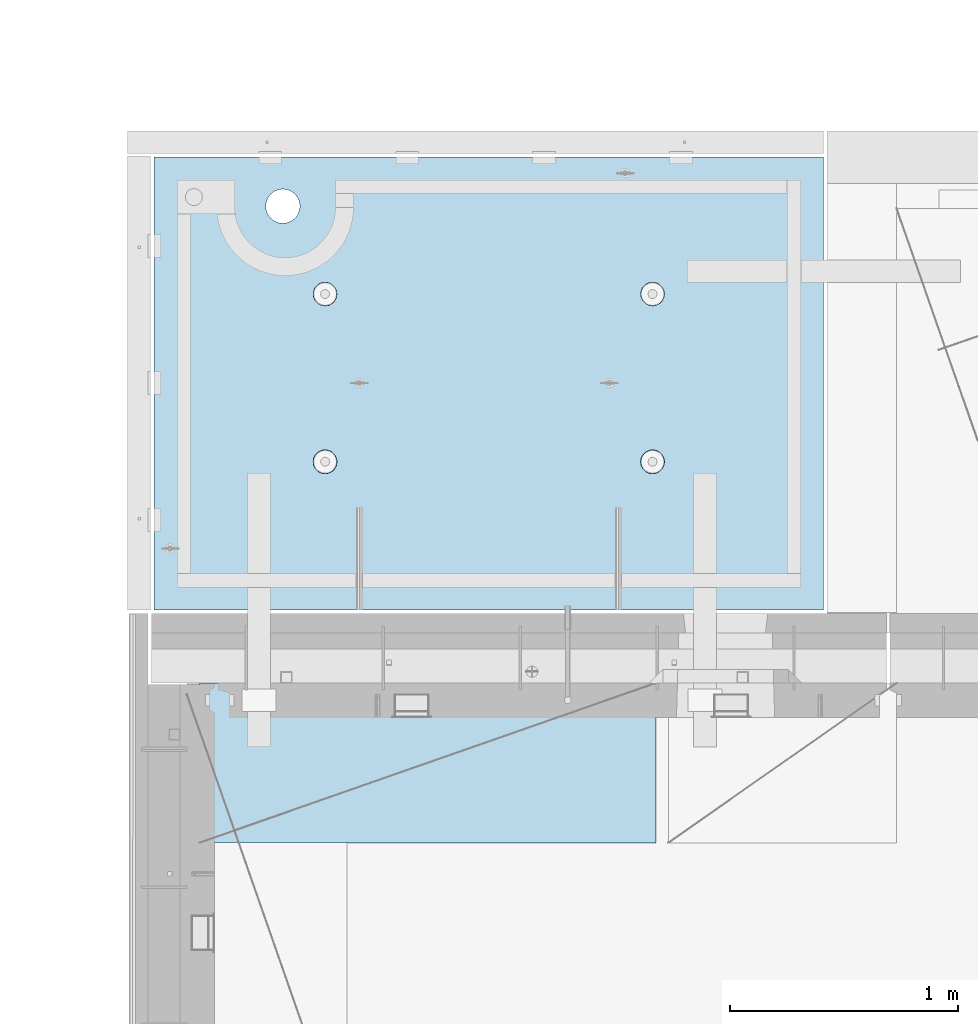
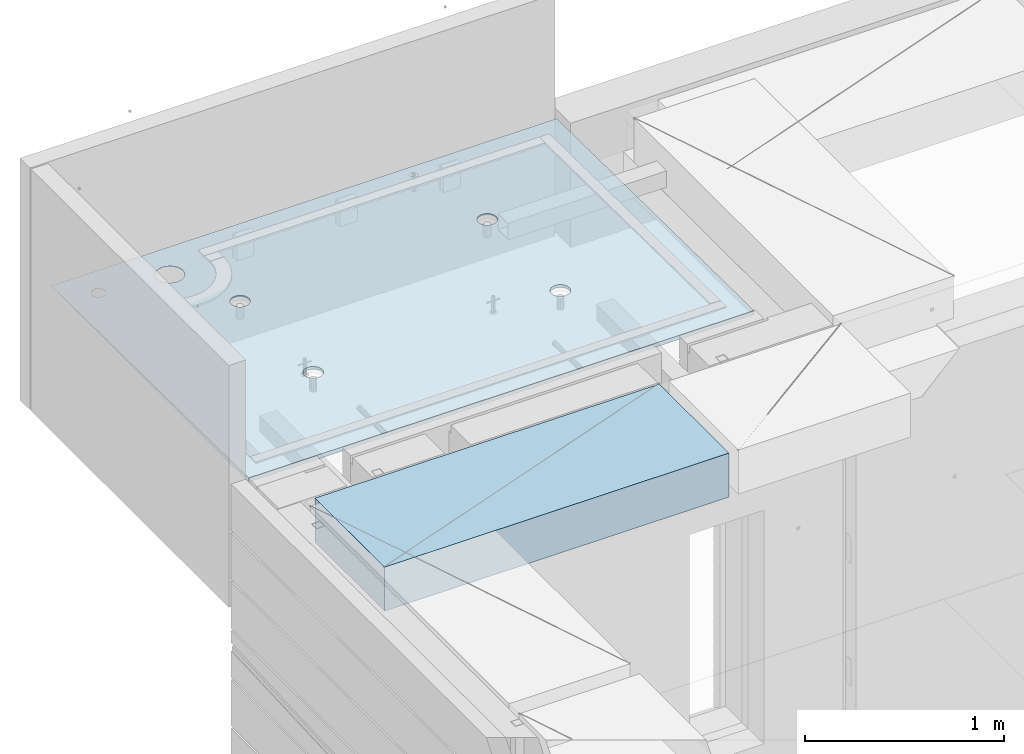
# One storey, part 184 of 325: 1 plate, 1 slab, 2 elements without a shape of their own.
"""IFC2X3 building model written with IfcOpenShell, lengths in millimetres."""

import ifcopenshell
import ifcopenshell.guid

model = None  # the IFC model being written
_history = None  # IfcOwnerHistory: only IFC2X3 demands one
_inside = {}  # id of a spatial element -> (the spatial element, [elements in it])
_under = {}  # id of a project, library or spatial element -> (it, [spatial elements below it])
_declared = {}  # id of a project -> (the project, [libraries it declares])
_typed = {}  # id of a type object -> (the type object, [elements of that type])
_made_of = {}  # id of a material, layer set ... -> (it, [elements and type objects made of it])


def new_model(schema):
    """Start an empty IFC model of exactly this schema.

    Asked for "IFC4X3", IfcOpenShell would pick the latest addendum, in which some entities
    have other attributes; the version numbers below select the first issue.
    IFC2X3 requires an IfcOwnerHistory on every rooted entity: one is made here for all.
    """
    global model, _history
    if schema == "IFC4X3":
        model = ifcopenshell.file(schema_version=(4, 3, 0, 0))
    else:
        model = ifcopenshell.file(schema=schema)
    _inside.clear()
    _under.clear()
    _declared.clear()
    _typed.clear()
    _made_of.clear()
    _history = None
    if model.schema == "IFC2X3":
        org = make("IfcOrganization", Name="unknown")
        user = make(
            "IfcPersonAndOrganization",
            ThePerson=make("IfcPerson", FamilyName="unknown"),
            TheOrganization=org,
        )
        app = make(
            "IfcApplication",
            ApplicationDeveloper=org,
            Version="unknown",
            ApplicationFullName="unknown",
            ApplicationIdentifier="unknown",
        )
        _history = make(
            "IfcOwnerHistory",
            OwningUser=user,
            OwningApplication=app,
            ChangeAction="ADDED",
            CreationDate=0,
        )
    return model


def make(cls, **values):
    """One entity of the class cls with the attributes given. An attribute that is None is left unset."""
    return model.create_entity(
        cls, **{name: value for name, value in values.items() if value is not None}
    )


def rooted(cls, **values):
    """An entity with a GlobalId (a new one), such as an element, a storey or a relation."""
    return make(cls, GlobalId=ifcopenshell.guid.new(), OwnerHistory=_history, **values)


def si_unit(unit_type, name, prefix=None):
    """IfcSIUnit, for example si_unit("LENGTHUNIT", "METRE", prefix="MILLI")."""
    return make("IfcSIUnit", UnitType=unit_type, Prefix=prefix, Name=name)


def assignment(units):
    """IfcUnitAssignment: the units of a project."""
    return None if units is None else make("IfcUnitAssignment", Units=units)


def point(xyz):
    """IfcCartesianPoint."""
    return None if xyz is None else make("IfcCartesianPoint", Coordinates=xyz)


def direction(xyz):
    """IfcDirection."""
    return None if xyz is None else make("IfcDirection", DirectionRatios=xyz)


def frame(location, z_axis=None, x_axis=None):
    """IfcAxis2Placement3D, a coordinate frame: its origin and axes. An axis left out is left unset."""
    return make(
        "IfcAxis2Placement3D",
        Location=point(location),
        Axis=direction(z_axis),
        RefDirection=direction(x_axis),
    )


def origin_with_axes():
    """The frame at (0, 0, 0) with the z axis (0, 0, 1) and the x axis (1, 0, 0) written out."""
    return frame((0.0, 0.0, 0.0), z_axis=(0.0, 0.0, 1.0), x_axis=(1.0, 0.0, 0.0))


def place(relative_to, where):
    """IfcLocalPlacement: puts the frame where relative to a parent placement (None: the world)."""
    return make(
        "IfcLocalPlacement", PlacementRelTo=relative_to, RelativePlacement=where
    )


def context(
    kind, dimensions, precision=None, world=None, true_north=None, identifier=None
):
    """IfcGeometricRepresentationContext, for example the 3D "Model" context."""
    return make(
        "IfcGeometricRepresentationContext",
        ContextIdentifier=identifier,
        ContextType=kind,
        CoordinateSpaceDimension=dimensions,
        Precision=precision,
        WorldCoordinateSystem=world,
        TrueNorth=true_north,
    )


def subcontext(parent, identifier, kind, view, scale=None):
    """IfcGeometricRepresentationSubContext, for example "Body" below "Model"."""
    return make(
        "IfcGeometricRepresentationSubContext",
        ContextIdentifier=identifier,
        ContextType=kind,
        ParentContext=parent,
        TargetScale=scale,
        TargetView=view,
    )


def project(units=None, contexts=None):
    """IfcProject with its units and contexts."""
    return rooted(
        "IfcProject",
        Name="project",
        RepresentationContexts=contexts,
        UnitsInContext=assignment(units),
    )


def spatial(cls, under=None, at=None, **own):
    """A site, building, storey or space (cls), placed at a placement, below another one or the project."""
    s = rooted(cls, ObjectPlacement=at, **own)
    if under is not None:
        _under.setdefault(under.id(), (under, []))[1].append(s)
    return s


def faces_of(points, faces, orient=None, outer=None):
    """IfcFace entities. A face is a list of loops; a loop is a list of indices into points, from 0.

    orient and outer hold one flag for each loop. By default every Orientation is true, the
    first loop of a face is its IfcFaceOuterBound and the others are IfcFaceBound.
    """
    made = []
    for i, loops in enumerate(faces):
        bounds = []
        for j, loop in enumerate(loops):
            is_outer = j == 0 if outer is None else outer[i][j]
            bounds.append(
                make(
                    "IfcFaceOuterBound" if is_outer else "IfcFaceBound",
                    Bound=make("IfcPolyLoop", Polygon=[points[k] for k in loop]),
                    Orientation=True if orient is None else orient[i][j],
                )
            )
        made.append(make("IfcFace", Bounds=bounds))
    return made


def faceted_brep(points, faces, orient=None, outer=None, voids=None):
    """IfcFacetedBrep: a solid bounded by flat faces; with voids (closed shells), ...WithVoids."""
    shared = [point(p) for p in points]
    hull = make("IfcClosedShell", CfsFaces=faces_of(shared, faces, orient, outer))
    if voids is None:
        return make("IfcFacetedBrep", Outer=hull)
    return make(
        "IfcFacetedBrepWithVoids",
        Outer=hull,
        Voids=[
            make(cls, CfsFaces=faces_of(shared, fs, o, b)) for cls, fs, o, b in voids
        ],
    )


def shape(context_of_items, identifier, shape_type, items):
    """IfcShapeRepresentation: the items that make up one representation, for example the "Body"."""
    return make(
        "IfcShapeRepresentation",
        ContextOfItems=context_of_items,
        RepresentationIdentifier=identifier,
        RepresentationType=shape_type,
        Items=items,
    )


def material(Name=None, Category=None):
    """IfcMaterial."""
    return make("IfcMaterial", Name=Name, Category=Category)


def made_of(thing, what):
    """Note that an element or type object is made of a material, layer set ...; save() writes the relation."""
    if what is not None:
        _made_of.setdefault(what.id(), (what, []))[1].append(thing)
    return thing


def type_object(cls, material=None, **own):
    """A type object (cls), such as IfcWallType, which elements share."""
    return made_of(rooted(cls, **own), material)


def element(
    cls,
    number,
    at=None,
    inside=None,
    cuts=None,
    type_object=None,
    material=None,
    context=None,
    identifier="Body",
    shape_type=None,
    held_by="IfcProductDefinitionShape",
    body=None,
    shapes=None,
    **own,
):
    """One element of the class cls, such as IfcWall. Its Tag is "e" and its number.

    at: its placement. inside: the storey or other place that contains it. cuts: it is an
    opening in that element (IfcRelVoidsElement). A single representation is given by context,
    identifier, shape_type and body (its items); several are given by shapes. held_by: the class
    of the entity that holds the representations. save() writes the other relations.
    """
    e = rooted(cls, Tag="e%d" % number, ObjectPlacement=at, **own)
    if body is not None:
        shapes = [shape(context, identifier, shape_type, body)]
    if shapes is not None:
        e.Representation = make(held_by, Representations=shapes)
    if inside is not None:
        _inside.setdefault(inside.id(), (inside, []))[1].append(e)
    if cuts is not None:
        rooted(
            "IfcRelVoidsElement", RelatingBuildingElement=cuts, RelatedOpeningElement=e
        )
    if type_object is not None:
        _typed.setdefault(type_object.id(), (type_object, []))[1].append(e)
    return made_of(e, material)


def aggregate(whole, parts):
    """IfcRelAggregates: a whole, such as a stair, and the parts it consists of."""
    return rooted("IfcRelAggregates", RelatingObject=whole, RelatedObjects=parts)


def save(model, path):
    """Write the relations noted so far, then the file.

    IfcRelAggregates (storeys below a building ...), IfcRelContainedInSpatialStructure (elements
    in a storey), IfcRelDefinesByType, IfcRelAssociatesMaterial and IfcRelDeclares: one each for
    every whole, place, type object, material and project.
    """
    for whole, parts in _under.values():
        aggregate(whole, parts)
    for where, things in _inside.values():
        rooted(
            "IfcRelContainedInSpatialStructure",
            RelatedElements=things,
            RelatingStructure=where,
        )
    for kind, things in _typed.values():
        rooted("IfcRelDefinesByType", RelatedObjects=things, RelatingType=kind)
    for what, things in _made_of.values():
        rooted("IfcRelAssociatesMaterial", RelatedObjects=things, RelatingMaterial=what)
    for by, libraries in _declared.values():
        rooted("IfcRelDeclares", RelatingContext=by, RelatedDefinitions=libraries)
    model.write(path)


model = new_model("IFC2X3")

# Units and contexts
model_context = context("Model", 3, precision=1e-05, world=origin_with_axes())
body_context = subcontext(model_context, "Body", "Model", "MODEL_VIEW")
ifc_project = project(units=[si_unit("LENGTHUNIT", "METRE", prefix="MILLI"), si_unit("AREAUNIT", "SQUARE_METRE"), si_unit("VOLUMEUNIT", "CUBIC_METRE"), si_unit("MASSUNIT", "GRAM", prefix="KILO"), si_unit("TIMEUNIT", "SECOND"), si_unit("PLANEANGLEUNIT", "RADIAN"), si_unit("SOLIDANGLEUNIT", "STERADIAN"), si_unit("THERMODYNAMICTEMPERATUREUNIT", "DEGREE_CELSIUS"), si_unit("LUMINOUSINTENSITYUNIT", "LUMEN")], contexts=[model_context])

# Site, building, storey
site_placement = place(None, origin_with_axes())
site = spatial("IfcSite", under=ifc_project, at=site_placement, CompositionType="ELEMENT")
building_placement = place(site_placement, origin_with_axes())
building = spatial("IfcBuilding", under=site, at=building_placement, CompositionType="ELEMENT")
storey_placement = place(building_placement, origin_with_axes())
storey = spatial("IfcBuildingStorey", under=building, at=storey_placement, Name="1", CompositionType="ELEMENT", Elevation=0.0)

# Assembly, slab
assembly_1_placement = place(storey_placement, origin_with_axes())
assembly_1 = element("IfcElementAssembly", 1, at=assembly_1_placement, inside=storey, AssemblyPlace="NOTDEFINED", PredefinedType="REINFORCEMENT_UNIT")
ifc_material_1 = material(Name="CONCRETE/C35/45")
slab_type = type_object("IfcSlabType", PredefinedType="NOTDEFINED")
slab_placement = place(assembly_1_placement, frame((7734.99985681325, 20899.9965573523, 84717.5), z_axis=(0.0, 1.0, 0.0), x_axis=(1.0, 0.0, 0.0)))
slab = element("IfcSlab", 2, at=slab_placement, type_object=slab_type, material=ifc_material_1, PredefinedType="FLOOR", context=body_context, shape_type="Brep", body=[
    faceted_brep([(209.64691778923, 10.1153411067935, 1795.66138892724), (209.64691778923, 12.5000000975269, 1795.66138892724), (201.519156607756, 12.5000000956934, 1783.49470026561), (201.519156607756, 9.96210853298544, 1783.49470026561), (189.354094229504, 12.5000000940054, 1775.36450517907), (189.354094229504, 9.85971331609471, 1775.36450517907), (175.003751124998, 12.5000000927103, 1772.50855216914), (175.003751124998, 9.82374419966072, 1772.50855216914), (160.652836945715, 12.5000000920118, 1775.36163419229), (160.652836945715, 9.85967715564766, 1775.36163419229), (148.48614828409, 12.5000000919972, 1783.48939537376), (148.48614828409, 9.96204171716818, 1783.48939537376), (140.355953197546, 12.5000000926811, 1795.65445775201), (140.355953197546, 10.1152538077149, 1795.65445775201), (137.500000187611, 12.5000000939617, 1810.00480085652), (137.500000187611, 10.2959882753639, 1810.00480085652), (140.353082210766, 12.5000000956497, 1824.35571503581), (140.353082210766, 10.4767299357773, 1824.35571503581), (148.48084339224, 12.5000000974687, 1836.52240369743), (148.48084339224, 10.6299625095853, 1836.52240369743), (160.645905770492, 12.5000000991568, 1844.65259878397), (160.645905770492, 10.7323577264906, 1844.65259878397), (174.996248874998, 12.5000001004519, 1847.50855179391), (174.996248874998, 10.76832684291, 1847.50855179391), (189.347163054282, 12.5000001011649, 1844.65546977075), (189.347163054282, 10.7323938869522, 1844.65546977075), (201.513851715907, 12.5000001011795, 1836.52770858928), (201.513851715907, 10.6300293254026, 1836.52770858928), (209.64404680245, 12.500000100481, 1824.36264621103), (209.64404680245, 10.4768172348558, 1824.36264621103), (212.499999812386, 12.5000000992004, 1810.01230310652), (212.499999812386, 10.2960827672068, 1810.01230310652), (7.41420080885291e-08, 12.4999999999927, 0.0), (-7.41420080885291e-08, -12.5, -3.63797880709171e-12), (0.0, 12.5, 1985.00366210938), (2935.0, 12.5, 0.0), (2935.0, 12.5000004097383, 1985.00366209901), (2935.0, -12.5, 0.0), (2234.62536650318, -4.11052952855243, 666.125174646004), (2233.6850359994, 12.5000001221924, 665.819642744358), (2236.1904762364, 12.5000001207372, 650.000915653603), (2237.19128609271, -4.31360546511132, 650.000915653603), (2227.20504000945, -3.927412769277, 680.664672078045), (2226.41396523543, 12.5000001231529, 680.089922611885), (2215.65867395993, -3.78214492548432, 692.198960124559), (2215.08900701139, 12.5000001235312, 691.414880835895), (2201.11650369535, -3.68890261078195, 699.602413590121), (2200.81872714385, 12.5000001232838, 698.685951599829), (2185.00000005312, -3.65677809614863, 702.153104825993), (2185.00000005312, 12.5000001224398, 701.19139183679), (2168.88349641084, -3.6889026130375, 699.602413590248), (2169.18127296234, 12.5000001210865, 698.685951599953), (2154.34132614616, -3.78214492976258, 692.198960124762), (2154.9109930947, 12.5000001193257, 691.414880836099), (2142.7949600965, -3.92741277518508, 680.664672078252), (2143.58603487053, 12.5000001173757, 680.089922612086), (2135.37463360266, -4.11052953547915, 666.125174646131), (2136.31496410644, 12.5000001153967, 665.819642744485), (2132.80871401309, -4.31360547240183, 650.000915653603), (2133.8095238694, 12.5000001135923, 650.000915653603), (2135.35163581154, -4.51677552006731, 633.869184225769), (2136.31496410626, 12.5000001121371, 634.182188562663), (2142.75774888357, -4.70013866545924, 619.310123700241), (2143.58603487023, 12.5000001111621, 619.911908694903), (2154.30411492676, -4.84571105932991, 607.751654332831), (2154.9109930944, 12.5000001107837, 608.586950470697), (2168.86049860927, -4.93919976030884, 600.328637761646), (2169.18127296215, 12.5000001110311, 601.315879706683), (2185.00000005312, -4.97141838613607, 597.770474083001), (2185.00000005312, 12.5000001118751, 598.810439469788), (2201.13950149693, -4.93919975805329, 600.328637761777), (2200.81872714404, 12.500000113243, 601.31587970681), (2215.69588517932, -4.84571105505165, 607.751654333038), (2215.08900701168, 12.5000001149892, 608.586950470901), (2227.24225122238, -4.70013865955116, 619.310123700448), (2226.41396523573, 12.5000001169392, 619.911908695103), (2234.6483642943, -4.5167755131406, 633.869184225896), (2233.68503599959, 12.5000001189328, 634.182188562787), (799.625366508852, -4.11052962872782, 666.125174647848), (798.685036005074, 12.5000000220316, 665.819642746203), (801.190476242367, 12.5000000205619, 650.000915653603), (802.19128609867, -4.31360556531581, 650.000915653603), (792.205040014274, -3.92741286943783, 680.664672081548), (791.41396524025, 12.500000022992, 680.089922615389), (780.658673963429, -3.78214502561605, 692.198960129379), (780.089007014889, 12.5000000233704, 691.414880840719), (766.116503697189, -3.68890271089913, 699.602413595789), (765.818727145695, 12.500000023123, 698.685951605497), (750.000000053116, -3.65677819628036, 702.153104831952), (750.000000053116, 12.500000022279, 701.191391842753), (733.883496409002, -3.68890271315468, 699.602413595916), (734.181272960497, 12.5000000209257, 698.685951605625), (719.341326142654, -3.78214502989431, 692.198960129586), (719.910993091196, 12.5000000191649, 691.414880840923), (707.794960091675, -3.9274128753168, 680.664672081755), (708.586034865702, 12.5000000172149, 680.089922615593), (700.374633596988, -4.11052963565453, 666.125174647976), (701.314964100775, 12.5000000152359, 665.819642746326), (697.808714007129, -4.31360557259177, 650.000915653603), (698.80952386344, 12.5000000134314, 650.000915653603), (700.351635805864, -4.51677562028635, 633.869184223928), (701.314964100589, 12.5000000119617, 634.182188560822), (707.757748878739, -4.70013876570738, 619.310123696734), (708.586034865404, 12.5000000110012, 619.911908691396), (719.304114923256, -4.84571115959261, 607.751654328004), (719.910993090896, 12.5000000106229, 608.586950465873), (733.860498607421, -4.93919986057153, 600.328637755971), (734.181272960313, 12.5000000108703, 601.315879701015), (750.000000053116, -4.97141848641331, 597.770474077031), (750.000000053116, 12.5000000117143, 598.810439463825), (766.13950149877, -4.93919985831599, 600.328637756098), (765.818727145879, 12.5000000130822, 601.315879701138), (780.695885182828, -4.8457111552998, 607.751654328211), (780.089007015189, 12.5000000148284, 608.586950466077), (792.242251227208, -4.7001387597993, 619.310123696941), (791.413965240548, 12.5000000167784, 619.9119086916), (799.648364299976, -4.51677561334509, 633.869184224055), (798.685036005258, 12.500000018772, 634.182188560946), (799.10144812637, 5.14425941386435, 1400.95677429027), (798.685035917459, 12.5000000978907, 1400.82147376184), (801.190476154532, 12.5000000964355, 1385.00274667064), (801.640278098052, 4.94332744530402, 1385.00274667064), (791.759461503394, 5.32544292352395, 1415.3427714214), (791.413965153277, 12.5000000988512, 1415.09175362977), (780.334995861451, 5.46917710648268, 1426.75528657348), (780.089006928914, 12.5000000992295, 1426.4167118541), (765.946354116128, 5.56143501828774, 1434.08057830477), (765.818727060978, 12.5000000989821, 1433.68778261824), (749.999999969796, 5.59322037934908, 1436.60434069568), (749.999999969796, 12.5000000981381, 1436.19322285528), (734.053645823422, 5.56143501607585, 1434.0805783049), (734.181272878572, 12.5000000967848, 1433.68778261837), (719.665004077991, 5.46917710226262, 1426.75528657369), (719.91099301053, 12.5000000950386, 1426.41671185431), (708.240538435917, 5.32544291768863, 1415.34277142161), (708.586034786036, 12.5000000930741, 1415.09175362997), (700.898551812832, 5.1442594070104, 1400.9567742904), (701.314964021747, 12.500000091095, 1400.82147376197), (698.359721841111, 4.94332743810082, 1385.00274667064), (698.809523784634, 12.500000089276, 1385.00274667064), (700.875796820188, 4.74230235200957, 1369.04132550559), (701.314964021563, 12.5000000878208, 1369.18401957925), (708.203720079233, 4.56087505744654, 1354.63597181773), (708.586034785736, 12.5000000868604, 1354.91373971109), (719.628185714913, 4.41683953967004, 1343.19953063831), (719.91099301023, 12.500000086482, 1343.58878148656), (734.030890820433, 4.32433784281602, 1335.85488233829), (734.181272878388, 12.5000000867294, 1336.31771072235), (749.999999969796, 4.292459364151, 1333.3237263947), (749.999999969796, 12.5000000875589, 1333.81227048538), (765.969109119118, 4.32433784505702, 1335.85488233842), (765.818727061163, 12.5000000889413, 1336.31771072247), (780.371814224529, 4.4168395439192, 1343.19953063852), (780.089006929215, 12.500000090673, 1343.58878148677), (791.796279860078, 4.5608750632673, 1354.63597181794), (791.413965153577, 12.5000000926375, 1354.91373971129), (799.124203119014, 4.74230235887808, 1369.04132550571), (798.685035917644, 12.5000000946166, 1369.18401957938), (2234.1014481207, 5.14425951402518, 1400.95677428843), (2233.68503591179, 12.5000001980516, 1400.82147376), (2236.19047614857, 12.5000001965964, 1385.00274667064), (2236.64027809209, 4.94332754549396, 1385.00274667064), (2226.75946149857, 5.32544302367023, 1415.3427714179), (2226.41396514845, 12.5000001990265, 1415.09175362627), (2215.33499585795, 5.46917720662896, 1426.75528656866), (2215.08900692541, 12.5000001993903, 1426.41671184928), (2200.94635411429, 5.56143511841947, 1434.0805782991), (2200.81872705914, 12.5000001991575, 1433.68778261257), (2184.9999999698, 5.5932204794517, 1436.60434068972), (2184.9999999698, 12.5000001982989, 1436.19322284931), (2169.05364582526, 5.56143511619302, 1434.08057829923), (2169.18127288041, 12.5000001969456, 1433.6877826127), (2154.66500408149, 5.46917720239435, 1426.75528656886), (2154.91099301403, 12.5000001951994, 1426.41671184948), (2143.24053844074, 5.32544301784947, 1415.3427714181), (2143.58603479086, 12.5000001932349, 1415.09175362647), (2135.8985518185, 5.14425950717123, 1400.95677428856), (2136.31496402742, 12.5000001912558, 1400.82147376013), (2133.35972184708, 4.94332753829076, 1385.00274667064), (2133.8095237906, 12.5000001894368, 1385.00274667064), (2135.87579682586, 4.74230245222861, 1369.04132550743), (2136.31496402723, 12.5000001879816, 1369.18401958109), (2143.20372008406, 4.56087515768013, 1354.63597182124), (2143.58603479056, 12.5000001870212, 1354.91373971459), (2154.62818571842, 4.41683963991818, 1343.19953064314), (2154.91099301373, 12.5000001866429, 1343.58878149139), (2169.03089082228, 4.32433794307872, 1335.85488234397), (2169.18127288023, 12.5000001868902, 1336.31771072802), (2184.9999999698, 4.2924594644137, 1333.32372640067), (2184.9999999698, 12.5000001877343, 1333.81227049134), (2200.96910911727, 4.32433794530516, 1335.85488234409), (2200.81872705932, 12.5000001891021, 1336.31771072814), (2215.37181422102, 4.41683964416734, 1343.19953064335), (2215.08900692571, 12.5000001908338, 1343.58878149159), (2226.79627985525, 4.56087516351545, 1354.63597182144), (2226.41396514875, 12.5000001927983, 1354.9137397148), (2234.12420311334, 4.74230245909712, 1369.04132550756), (2233.68503591197, 12.5000001947919, 1369.18401958122), (629.950843674942, 9.32008998414676, 1732.51833148514), (618.0319469801, 9.12446051153529, 1716.98532289615), (602.498938391109, 8.97434873710154, 1705.06642620131), (584.410366773798, 8.87998453022738, 1697.57389451346), (564.998938391109, 8.84779865563905, 1695.01833148514), (545.587510008419, 8.87998452752072, 1697.57389451346), (527.498938391109, 8.97434873186285, 1705.06642620131), (511.965929802118, 9.12446050412836, 1716.98532289615), (500.047033107276, 9.32008997508092, 1732.51833148514), (492.554501419429, 9.54790531957406, 1750.60690310245), (489.998938391109, 9.79238129836449, 1770.01833148514), (492.554501419429, 10.0368572775042, 1789.42975986783), (500.047033107276, 10.264672623045, 1807.51833148514), (511.965929802118, 10.4603020956565, 1823.05134007413), (527.498938391109, 10.6104138700903, 1834.97023676898), (545.587510008419, 10.7047780769644, 1842.46276845682), (564.998938391109, 10.7369639515528, 1845.01833148514), (584.410366773798, 10.7047780796856, 1842.46276845682), (602.498938391109, 10.610413875329, 1834.97023676898), (618.0319469801, 10.4603021030634, 1823.05134007413), (629.950843674942, 10.2646726321109, 1807.51833148514), (637.443375362789, 10.0368572876178, 1789.42975986783), (639.998938391109, 9.79238130884187, 1770.01833148514), (637.443375362789, 9.54790532968764, 1750.60690310245), (629.950843674942, 12.500000128086, 1807.51833148514), (637.443375362789, 12.5000001267326, 1789.42975986783), (618.0319469801, 12.5000001288572, 1823.05134007413), (602.498938391109, 12.5000001290027, 1834.97023676898), (584.410366773798, 12.500000128508, 1842.46276845682), (564.998938391109, 12.5000001274166, 1845.01833148514), (545.587510008419, 12.5000001258013, 1842.46276845682), (527.498938391109, 12.500000123764, 1834.97023676898), (511.965929802118, 12.5000001214503, 1823.05134007413), (500.047033107276, 12.5000001190201, 1807.51833148514), (492.554501419429, 12.5000001166336, 1789.42975986783), (489.998938391109, 12.5000001144508, 1770.01833148514), (492.554501419429, 12.5000001126173, 1750.60690310245), (500.047033107276, 12.5000001112785, 1732.51833148514), (511.965929802118, 12.5000001105072, 1716.98532289615), (527.498938391109, 12.5000001103617, 1705.06642620131), (545.587510008419, 12.5000001108419, 1697.57389451346), (564.998938391109, 12.5000001119333, 1695.01833148514), (584.410366773798, 12.5000001135631, 1697.57389451346), (602.498938391109, 12.5000001156004, 1705.06642620131), (618.0319469801, 12.5000001179142, 1716.98532289615), (629.950843674942, 12.5000001203443, 1732.51833148514), (637.443375362789, 12.5000001227309, 1750.60690310245), (639.998938391109, 12.5000001249136, 1770.01833148514)], [[[0, 1, 2, 3]], [[3, 2, 4, 5]], [[5, 4, 6, 7]], [[7, 6, 8, 9]], [[9, 8, 10, 11]], [[11, 10, 12, 13]], [[13, 12, 14, 15]], [[15, 14, 16, 17]], [[17, 16, 18, 19]], [[19, 18, 20, 21]], [[21, 20, 22, 23]], [[23, 22, 24, 25]], [[25, 24, 26, 27]], [[27, 26, 28, 29]], [[29, 28, 30, 31]], [[31, 30, 1, 0]], [[32, 33, 34]], [[35, 36, 37]], [[32, 35, 37, 33]], [[38, 39, 40, 41]], [[42, 43, 39, 38]], [[44, 45, 43, 42]], [[46, 47, 45, 44]], [[48, 49, 47, 46]], [[50, 51, 49, 48]], [[51, 50, 52, 53]], [[53, 52, 54, 55]], [[55, 54, 56, 57]], [[57, 56, 58, 59]], [[59, 58, 60, 61]], [[61, 60, 62, 63]], [[63, 62, 64, 65]], [[65, 64, 66, 67]], [[67, 66, 68, 69]], [[70, 71, 69, 68]], [[72, 73, 71, 70]], [[74, 75, 73, 72]], [[76, 77, 75, 74]], [[41, 40, 77, 76]], [[78, 79, 80, 81]], [[82, 83, 79, 78]], [[84, 85, 83, 82]], [[86, 87, 85, 84]], [[88, 89, 87, 86]], [[90, 91, 89, 88]], [[91, 90, 92, 93]], [[93, 92, 94, 95]], [[95, 94, 96, 97]], [[97, 96, 98, 99]], [[99, 98, 100, 101]], [[101, 100, 102, 103]], [[103, 102, 104, 105]], [[105, 104, 106, 107]], [[107, 106, 108, 109]], [[110, 111, 109, 108]], [[112, 113, 111, 110]], [[114, 115, 113, 112]], [[116, 117, 115, 114]], [[81, 80, 117, 116]], [[118, 119, 120, 121]], [[122, 123, 119, 118]], [[124, 125, 123, 122]], [[126, 127, 125, 124]], [[128, 129, 127, 126]], [[130, 131, 129, 128]], [[132, 133, 131, 130]], [[134, 135, 133, 132]], [[135, 134, 136, 137]], [[137, 136, 138, 139]], [[139, 138, 140, 141]], [[141, 140, 142, 143]], [[143, 142, 144, 145]], [[145, 144, 146, 147]], [[147, 146, 148, 149]], [[149, 148, 150, 151]], [[152, 153, 151, 150]], [[154, 155, 153, 152]], [[156, 157, 155, 154]], [[121, 120, 157, 156]], [[158, 159, 160, 161]], [[162, 163, 159, 158]], [[164, 165, 163, 162]], [[166, 167, 165, 164]], [[168, 169, 167, 166]], [[170, 171, 169, 168]], [[172, 173, 171, 170]], [[174, 175, 173, 172]], [[175, 174, 176, 177]], [[177, 176, 178, 179]], [[179, 178, 180, 181]], [[181, 180, 182, 183]], [[183, 182, 184, 185]], [[185, 184, 186, 187]], [[187, 186, 188, 189]], [[189, 188, 190, 191]], [[192, 193, 191, 190]], [[194, 195, 193, 192]], [[196, 197, 195, 194]], [[161, 160, 197, 196]], [[36, 34, 33, 37], [3, 5, 7, 9, 11, 13, 15, 17, 19, 21, 23, 25, 27, 29, 31, 0], [198, 199, 200, 201, 202, 203, 204, 205, 206, 207, 208, 209, 210, 211, 212, 213, 214, 215, 216, 217, 218, 219, 220, 221], [194, 192, 190, 188, 186, 184, 182, 180, 178, 176, 174, 172, 170, 168, 166, 164, 162, 158, 161, 196], [154, 152, 150, 148, 146, 144, 142, 140, 138, 136, 134, 132, 130, 128, 126, 124, 122, 118, 121, 156], [114, 112, 110, 108, 106, 104, 102, 100, 98, 96, 94, 92, 90, 88, 86, 84, 82, 78, 81, 116], [74, 72, 70, 68, 66, 64, 62, 60, 58, 56, 54, 52, 50, 48, 46, 44, 42, 38, 41, 76]], [[218, 222, 223, 219]], [[217, 224, 222, 218]], [[216, 225, 224, 217]], [[215, 226, 225, 216]], [[214, 227, 226, 215]], [[213, 228, 227, 214]], [[212, 229, 228, 213]], [[211, 230, 229, 212]], [[210, 231, 230, 211]], [[209, 232, 231, 210]], [[208, 233, 232, 209]], [[207, 234, 233, 208]], [[206, 235, 234, 207]], [[205, 236, 235, 206]], [[204, 237, 236, 205]], [[203, 238, 237, 204]], [[202, 239, 238, 203]], [[201, 240, 239, 202]], [[200, 241, 240, 201]], [[199, 242, 241, 200]], [[198, 243, 242, 199]], [[221, 244, 243, 198]], [[220, 245, 244, 221]], [[219, 223, 245, 220]], [[35, 32, 34, 36], [26, 24, 22, 20, 18, 16, 14, 12, 10, 8, 6, 4, 2, 1, 30, 28], [222, 224, 225, 226, 227, 228, 229, 230, 231, 232, 233, 234, 235, 236, 237, 238, 239, 240, 241, 242, 243, 244, 245, 223], [163, 165, 167, 169, 171, 173, 175, 177, 179, 181, 183, 185, 187, 189, 191, 193, 195, 197, 160, 159], [123, 125, 127, 129, 131, 133, 135, 137, 139, 141, 143, 145, 147, 149, 151, 153, 155, 157, 120, 119], [83, 85, 87, 89, 91, 93, 95, 97, 99, 101, 103, 105, 107, 109, 111, 113, 115, 117, 80, 79], [43, 45, 47, 49, 51, 53, 55, 57, 59, 61, 63, 65, 67, 69, 71, 73, 75, 77, 40, 39]]]),
])
aggregate(assembly_1, [slab])

# Assembly, plate
assembly_2_placement = place(storey_placement, origin_with_axes())
assembly_2 = element("IfcElementAssembly", 3, at=assembly_2_placement, inside=storey, Name="Steel Assembly", AssemblyPlace="NOTDEFINED", PredefinedType="NOTDEFINED")
ifc_material_2 = material()
plate_type = type_object("IfcPlateType", PredefinedType="NOTDEFINED")
plate_placement = place(assembly_2_placement, frame((9935.0, 20580.0001220703, 84595.3), z_axis=(0.0, -1.0, 0.0), x_axis=(-1.0, 3.00000001838171e-08, 0.0)))
plate = element("IfcPlate", 4, at=plate_placement, type_object=plate_type, material=ifc_material_2, Name="RE1", context=body_context, shape_type="Brep", body=[
    faceted_brep([(1.81898940354586e-12, -135.0, 1.81898940354586e-12), (0.0, -135.0, 699.999999999996), (0.0, 135.0, 699.999999999996), (1.81898940354586e-12, 135.0, 1.81898940354586e-12), (1999.99951171875, -135.0, 699.999999999993), (1999.99951171875, 135.0, 699.999999999993), (2000.0, -135.0, -3.63797880709171e-12), (2000.0, 135.0, -3.63797880709171e-12)], [[[0, 1, 2, 3]], [[1, 4, 5, 2]], [[4, 6, 7, 5]], [[6, 0, 3, 7]], [[5, 7, 3, 2]], [[6, 4, 1, 0]]]),
])
aggregate(assembly_2, [plate])

save(model, "model.ifc")
